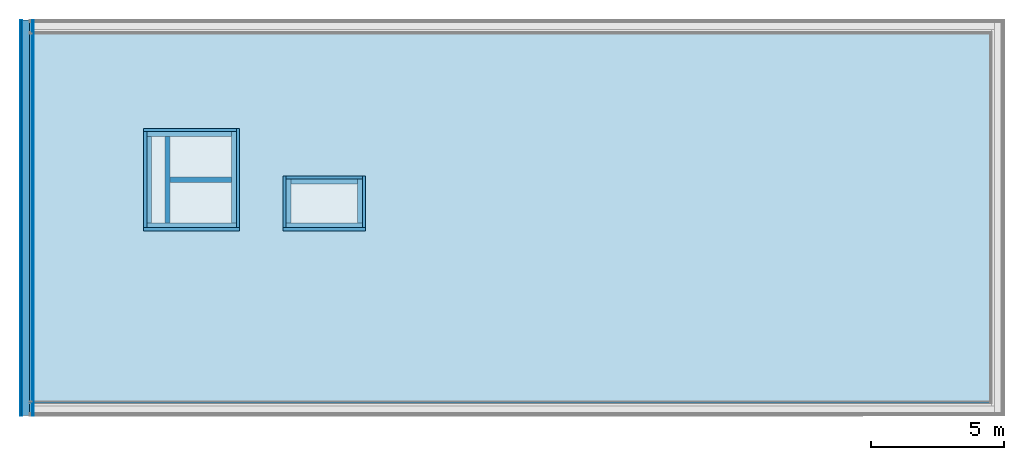
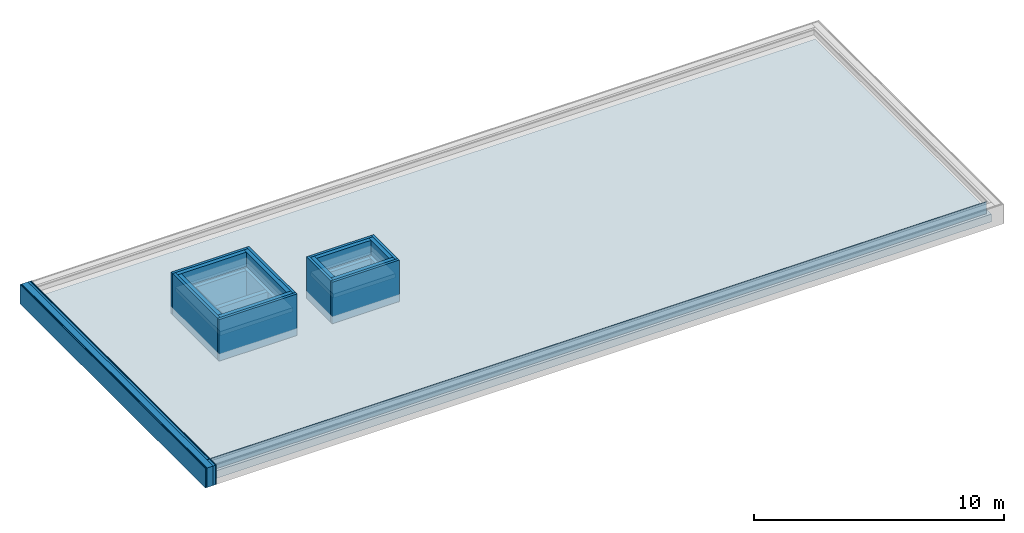
# One storey, part 1 of 3: 25 building element parts, 3 roofs, 2 walls, 10 elements without a shape of their own.
"""IFC4 building model written with IfcOpenShell, lengths in metres."""

from ifc_helpers import new_model, entity, si_unit, converted_unit, derived_unit, direction, frame, origin_with_axes, place, context, subcontext, project, spatial, polygons, material, type_object, element, aggregate, save


model = new_model("IFC4")

# Units and contexts
model_context = context("Model", 3, precision=1e-05, world=origin_with_axes(), true_north=direction((0.0, 1.0)))
body_context = subcontext(model_context, "Body", "Model", "MODEL_VIEW")
ifc_project = project(units=[si_unit("LENGTHUNIT", "METRE"), si_unit("AREAUNIT", "SQUARE_METRE"), si_unit("VOLUMEUNIT", "CUBIC_METRE"), converted_unit("PLANEANGLEUNIT", "DEGREE", entity("IfcPlaneAngleMeasure", 0.0174532925199433), si_unit("PLANEANGLEUNIT", "RADIAN"), dimensions=[0, 0, 0, 0, 0, 0, 0]), converted_unit("TIMEUNIT", "Year", entity("IfcTimeMeasure", 31557600.0), si_unit("TIMEUNIT", "SECOND"), dimensions=[0, 0, 1, 0, 0, 0, 0]), si_unit("MASSUNIT", "GRAM", prefix="KILO"), si_unit("THERMODYNAMICTEMPERATUREUNIT", "DEGREE_CELSIUS"), si_unit("LUMINOUSINTENSITYUNIT", "LUMEN"), si_unit("ENERGYUNIT", "JOULE", prefix="MEGA"), derived_unit("THERMALCONDUCTANCEUNIT", [(si_unit("POWERUNIT", "WATT"), 1), (si_unit("LENGTHUNIT", "METRE"), -1), (si_unit("THERMODYNAMICTEMPERATUREUNIT", "KELVIN"), -1)]), derived_unit("SPECIFICHEATCAPACITYUNIT", [(si_unit("ENERGYUNIT", "JOULE"), 1), (si_unit("MASSUNIT", "GRAM", prefix="KILO"), -1), (si_unit("THERMODYNAMICTEMPERATUREUNIT", "KELVIN"), -1)]), derived_unit("MASSDENSITYUNIT", [(si_unit("MASSUNIT", "GRAM", prefix="KILO"), 1), (si_unit("VOLUMEUNIT", "CUBIC_METRE"), -1)])], contexts=[model_context])

# Site, building, storey
site_placement = place(None, origin_with_axes())
site = spatial("IfcSite", under=ifc_project, at=site_placement, CompositionType="ELEMENT")
building_placement = place(site_placement, origin_with_axes())
building = spatial("IfcBuilding", under=site, at=building_placement, CompositionType="ELEMENT")
storey_placement = place(building_placement, frame((0.0, 0.0, 13.5), z_axis=(0.0, 0.0, 1.0), x_axis=(1.0, 0.0, 0.0)))
storey = spatial("IfcBuildingStorey", under=building, at=storey_placement, Name="Dach", CompositionType="ELEMENT", Elevation=13.5)

# Walls
ifc_material_1 = material(Name="Stahlbeton")
wall_type_1 = type_object("IfcWallType", Name="Stahlbeton 200", PredefinedType="NOTDEFINED")
wall_1_placement = place(storey_placement, frame((29.138, 8.854999945467554, 0.0), z_axis=(0.0, 0.0, 1.0), x_axis=(1.0, 0.0, 0.0)))
element("IfcWall", 1, at=wall_1_placement, inside=storey, type_object=wall_type_1, material=ifc_material_1, Name="Wand-001", PredefinedType="NOTDEFINED", context=body_context, shape_type="Tessellation", body=[
    polygons([(0.0, 0.09999999999999964, 0.0), (2.320000000000004, 0.09999999999999964, 0.0), (2.320000000000004, -0.09999999999999964, 0.0), (0.0, -0.09999999999999964, 0.0), (0.0, 0.09999999999999964, 1.5), (2.320000000000004, 0.09999999999999964, 1.5), (2.320000000000004, -0.09999999999999964, 1.5), (0.0, -0.09999999999999964, 1.5)], [[[1, 2, 3, 4]], [[5, 6, 2, 1]], [[7, 3, 2, 6]], [[4, 3, 7, 8]], [[8, 5, 1, 4]], [[8, 7, 6, 5]]], closed=True),
])
wall_type_2 = type_object("IfcWallType", Name="Stahlbeton 180", PredefinedType="NOTDEFINED")
wall_2_placement = place(storey_placement, frame((29.138, 6.934999945467554, 0.0), z_axis=(0.0, 0.0, 1.0), x_axis=(0.0, 1.0, 0.0)))
element("IfcWall", 2, at=wall_2_placement, inside=storey, type_object=wall_type_2, material=ifc_material_1, Name="Wand-001", PredefinedType="NOTDEFINED", context=body_context, shape_type="Tessellation", body=[
    polygons([(0.2999999999999998, 0.1799999999999997, 0.0), (3.540000000000001, 0.1799999999999997, 0.0), (3.540000000000001, 0.0, 0.0), (0.2999999999999998, 0.0, 0.0), (0.2999999999999998, 0.1799999999999997, 1.5), (3.540000000000001, 0.1799999999999997, 1.5), (3.540000000000001, 0.0, 1.5), (0.2999999999999998, 0.0, 1.5)], [[[1, 2, 3, 4]], [[5, 6, 2, 1]], [[7, 3, 2, 6]], [[4, 3, 7, 8]], [[8, 5, 1, 4]], [[8, 7, 6, 5]]], closed=True),
])

# Roofs
ifc_material_2 = material(Name="Stahlbeton Decke")
roof_type_1 = type_object("IfcRoofType", Name="Stahlbeton Decke 370", PredefinedType="FLAT_ROOF")
roof_1_placement = place(storey_placement, frame((23.88799999999999, 0.3629999999999995, 0.370000000000001), z_axis=(0.0, 0.0, 1.0), x_axis=(1.0, 0.0, 0.0)))
element("IfcRoof", 3, at=roof_1_placement, inside=storey, type_object=roof_type_1, material=ifc_material_2, Name="Decke-001", PredefinedType="FLAT_ROOF", context=body_context, shape_type="Tessellation", body=[
    polygons([(0.0, 0.0, 0.0), (0.0, 0.0, -0.3699999999999992), (36.19499999999999, 0.0, -0.3699999999999992), (36.19499999999999, 0.0, 0.0), (0.0, 14.11999989093511, 0.0), (0.0, 14.11999989093511, -0.3699999999999992), (36.19499999999999, 14.11999989093511, -0.3699999999999992), (7.750000000000011, 10.29199994546755, -0.3699999999999992), (4.390000000000011, 10.29199994546755, -0.3699999999999992), (4.390000000000011, 6.691999945467556, -0.3699999999999992), (7.750000000000011, 6.691999945467556, -0.3699999999999992), (12.485, 6.691999945467553, -0.3699999999999992), (12.485, 8.50999994546756, -0.3699999999999992), (9.617, 8.50999994546756, -0.3699999999999992), (9.617, 6.691999945467553, -0.3699999999999992), (36.19499999999999, 14.11999989093511, 0.0), (4.390000000000011, 6.691999945467556, 0.0), (4.390000000000011, 10.29199994546755, 0.0), (7.750000000000011, 10.29199994546755, 0.0), (7.750000000000011, 6.691999945467556, 0.0), (9.617, 8.50999994546756, 0.0), (12.485, 8.50999994546756, 0.0), (12.485, 6.691999945467553, 0.0), (9.617, 6.691999945467553, 0.0)], [[[1, 2, 3, 4]], [[5, 6, 2, 1]], [[3, 2, 6, 7], [8, 9, 10, 11], [12, 13, 14, 15]], [[4, 3, 7, 16]], [[5, 1, 4, 16], [17, 18, 19, 20], [21, 22, 23, 24]], [[16, 7, 6, 5]], [[18, 9, 8, 19]], [[17, 10, 9, 18]], [[20, 11, 10, 17]], [[19, 8, 11, 20]], [[22, 13, 12, 23]], [[21, 14, 13, 22]], [[24, 15, 14, 21]], [[23, 12, 15, 24]]], closed=True),
])
roof_type_2 = type_object("IfcRoofType", Name="Stahlbeton Decke 200", PredefinedType="FLAT_ROOF")
roof_2_placement = place(storey_placement, frame((28.27800000000001, 7.054999945467558, 1.699999999999999), z_axis=(0.0, 0.0, 1.0), x_axis=(1.0, 0.0, 0.0)))
element("IfcRoof", 4, at=roof_2_placement, inside=storey, type_object=roof_type_2, material=ifc_material_2, Name="Decke-001", PredefinedType="FLAT_ROOF", context=body_context, shape_type="Tessellation", body=[
    polygons([(0.0, 0.0, 0.0), (0.0, 0.0, -0.1999999999999993), (3.359999999999996, 0.0, -0.1999999999999993), (3.359999999999996, 0.0, 0.0), (0.0, 3.599999999999993, 0.0), (0.0, 3.599999999999993, -0.1999999999999993), (3.359999999999996, 3.599999999999993, -0.1999999999999993), (3.359999999999996, 3.599999999999993, 0.0)], [[[1, 2, 3, 4]], [[5, 6, 2, 1]], [[3, 2, 6, 7]], [[4, 3, 7, 8]], [[5, 1, 4, 8]], [[8, 7, 6, 5]]], closed=True),
])
roof_3_placement = place(storey_placement, frame((33.505, 7.054999945467557, 1.699999999999999), z_axis=(0.0, 0.0, 1.0), x_axis=(1.0, 0.0, 0.0)))
element("IfcRoof", 5, at=roof_3_placement, inside=storey, type_object=roof_type_2, material=ifc_material_2, Name="Decke-001", PredefinedType="FLAT_ROOF", context=body_context, shape_type="Tessellation", body=[
    polygons([(0.0, 0.0, 0.0), (0.0, 0.0, -0.1999999999999993), (2.868000000000002, 0.0, -0.1999999999999993), (2.868000000000002, 0.0, 0.0), (0.0, 1.818000000000003, 0.0), (0.0, 1.818000000000003, -0.1999999999999993), (2.868000000000002, 1.818000000000003, -0.1999999999999993), (2.868000000000002, 1.818000000000003, 0.0)], [[[1, 2, 3, 4]], [[5, 6, 2, 1]], [[3, 2, 6, 7]], [[4, 3, 7, 8]], [[5, 1, 4, 8]], [[8, 7, 6, 5]]], closed=True),
])

# Wall, building element parts
wall_type_3 = type_object("IfcWallType", Name="AW 300", PredefinedType="NOTDEFINED")
wall_3_placement = place(storey_placement, frame((28.158, 6.934999945467554, 0.0), z_axis=(0.0, 0.0, 1.0), x_axis=(1.0, 0.0, 0.0)))
wall_3 = element("IfcWall", 6, at=wall_3_placement, inside=storey, type_object=wall_type_3, Name="Wand-001", PredefinedType="NOTDEFINED")
ifc_material_3 = material(Name="Stahlbeton Wand")
building_element_part_1_placement = place(wall_3_placement, origin_with_axes())
building_element_part_1 = element("IfcBuildingElementPart", 7, at=building_element_part_1_placement, material=ifc_material_3, Name="Stahlbeton Wand", PredefinedType="NOTDEFINED", context=body_context, shape_type="Tessellation", body=[
    polygons([(0.1200000000000045, 0.2999999999999998, 1.5), (3.48, 0.3000000000000016, 1.5), (3.48, 0.3000000000000007, 0.0), (0.1199999999999974, 0.2999999999999998, 0.0), (3.480000000000004, 0.1200000000000045, 1.5), (0.1200000000000081, 0.1200000000000037, 1.5), (3.480000000000004, 0.120000000000001, 0.0), (0.120000000000001, 0.1200000000000001, 0.0)], [[[1, 2, 3, 4]], [[5, 2, 1, 6]], [[2, 5, 7, 3]], [[3, 7, 8, 4]], [[6, 1, 4, 8]], [[5, 6, 8, 7]]], closed=True),
    polygons([(3.480000000000004, 0.1200000000000045, 1.699999999999999), (3.48, 0.3000000000000016, 1.699999999999999), (3.48, 0.3000000000000016, 2.4), (3.480000000000004, 0.120000000000001, 2.4), (0.1200000000000045, 0.2999999999999998, 1.699999999999999), (0.1200000000000081, 0.1200000000000037, 1.699999999999999), (0.1199999999999974, 0.2999999999999998, 2.4), (0.120000000000001, 0.1200000000000001, 2.4)], [[[1, 2, 3, 4]], [[5, 2, 1, 6]], [[2, 5, 7, 3]], [[4, 3, 7, 8]], [[6, 1, 4, 8]], [[5, 6, 8, 7]]], closed=True),
])
ifc_material_4 = material(Name="XPS")
building_element_part_2_placement = place(wall_3_placement, origin_with_axes())
building_element_part_2 = element("IfcBuildingElementPart", 8, at=building_element_part_2_placement, material=ifc_material_4, Name="XPS", PredefinedType="NOTDEFINED", context=body_context, shape_type="Tessellation", body=[
    polygons([(3.600000000000005, 0.0, 0.370000000000001), (3.600000000000005, 0.120000000000001, 0.370000000000001), (3.600000000000005, 0.120000000000001, 2.4), (3.600000000000005, 0.0, 2.4), (3.480000000000004, 0.1200000000000019, 0.370000000000001), (0.0, 0.0, 0.370000000000001), (0.0, 0.1200000000000001, 0.370000000000001), (0.1200000000000045, 0.120000000000001, 0.370000000000001), (0.0, 0.1200000000000001, 2.4), (0.0, 0.0, 2.4)], [[[1, 2, 3, 4]], [[5, 2, 1, 6, 7, 8]], [[8, 7, 9, 3, 2, 5]], [[4, 3, 9, 10]], [[6, 1, 4, 10]], [[7, 6, 10, 9]]], closed=True),
])
aggregate(wall_3, [building_element_part_1, building_element_part_2])

# Wall, building element part
wall_4_placement = place(storey_placement, frame((31.75800000000001, 6.934999945467553, 0.0), z_axis=(0.0, 0.0, 1.0), x_axis=(0.0, 1.0, 0.0)))
wall_4 = element("IfcWall", 9, at=wall_4_placement, inside=storey, type_object=wall_type_3, Name="Wand-002", PredefinedType="NOTDEFINED")
building_element_part_3_placement = place(wall_4_placement, origin_with_axes())
building_element_part_3 = element("IfcBuildingElementPart", 10, at=building_element_part_3_placement, material=ifc_material_3, Name="Stahlbeton Wand", PredefinedType="NOTDEFINED", context=body_context, shape_type="Tessellation", body=[
    polygons([(3.719999999999999, 0.2999999999999972, 1.5), (3.719999999999999, 0.1199999999999974, 1.5), (3.720000000000004, 0.1199999999999974, 0.0), (3.720000000000004, 0.2999999999999972, 0.0), (0.2999999999999998, 0.120000000000001, 1.5), (0.2999999999999998, 0.3000000000000007, 1.5), (0.2999999999999998, 0.120000000000001, 0.0), (0.2999999999999998, 0.3000000000000007, 0.0)], [[[1, 2, 3, 4]], [[5, 2, 1, 6]], [[2, 5, 7, 3]], [[4, 3, 7, 8]], [[6, 1, 4, 8]], [[5, 6, 8, 7]]], closed=True),
    polygons([(0.2999999999999998, 0.120000000000001, 1.699999999999999), (3.719999999999999, 0.1199999999999974, 1.699999999999999), (3.720000000000004, 0.1199999999999974, 2.4), (0.2999999999999998, 0.120000000000001, 2.4), (3.719999999999999, 0.2999999999999972, 1.699999999999999), (0.2999999999999998, 0.3000000000000007, 1.699999999999999), (3.720000000000004, 0.2999999999999972, 2.4), (0.2999999999999998, 0.3000000000000007, 2.4)], [[[1, 2, 3, 4]], [[5, 2, 1, 6]], [[2, 5, 7, 3]], [[3, 7, 8, 4]], [[6, 1, 4, 8]], [[5, 6, 8, 7]]], closed=True),
])

# Wall, building element parts
wall_5_placement = place(storey_placement, frame((31.758, 10.77499994546756, 0.0), z_axis=(0.0, 0.0, 1.0), x_axis=(-1.0, 0.0, 0.0)))
wall_5 = element("IfcWall", 11, at=wall_5_placement, inside=storey, type_object=wall_type_3, Name="Wand-003", PredefinedType="NOTDEFINED")
building_element_part_4_placement = place(wall_5_placement, origin_with_axes())
building_element_part_4 = element("IfcBuildingElementPart", 12, at=building_element_part_4_placement, material=ifc_material_3, Name="Stahlbeton Wand", PredefinedType="NOTDEFINED", context=body_context, shape_type="Tessellation", body=[
    polygons([(3.479999999999993, 0.1200000000000045, 1.5), (0.3000000000000007, 0.1200000000000045, 1.5), (0.3000000000000007, 0.1199999999999992, 0.0), (3.479999999999997, 0.1199999999999992, 0.0), (0.3000000000000007, 0.3000000000000007, 1.5), (3.479999999999993, 0.3000000000000007, 1.5), (0.3000000000000007, 0.3000000000000007, 0.0), (3.479999999999997, 0.2999999999999989, 0.0)], [[[1, 2, 3, 4]], [[5, 2, 1, 6]], [[2, 5, 7, 3]], [[8, 4, 3, 7]], [[6, 1, 4, 8]], [[5, 6, 8, 7]]], closed=True),
    polygons([(0.3000000000000007, 0.3000000000000007, 1.699999999999999), (0.3000000000000007, 0.1200000000000045, 1.699999999999999), (0.3000000000000007, 0.120000000000001, 2.4), (0.3000000000000007, 0.3000000000000007, 2.4), (3.479999999999993, 0.1200000000000045, 1.699999999999999), (3.479999999999993, 0.3000000000000007, 1.699999999999999), (3.479999999999997, 0.1199999999999992, 2.4), (3.479999999999997, 0.3000000000000007, 2.4)], [[[1, 2, 3, 4]], [[5, 2, 1, 6]], [[2, 5, 7, 3]], [[7, 8, 4, 3]], [[6, 1, 4, 8]], [[5, 6, 8, 7]]], closed=True),
])
building_element_part_5_placement = place(wall_5_placement, origin_with_axes())
building_element_part_5 = element("IfcBuildingElementPart", 13, at=building_element_part_5_placement, material=ifc_material_4, Name="XPS", PredefinedType="NOTDEFINED", context=body_context, shape_type="Tessellation", body=[
    polygons([(0.1199999999999974, 0.1200000000000045, 0.370000000000001), (0.120000000000001, 0.0, 0.370000000000001), (0.120000000000001, 0.0, 2.4), (0.120000000000001, 0.120000000000001, 2.4), (3.599999999999998, 0.0, 0.370000000000001), (3.479999999999997, 0.1200000000000045, 0.370000000000001), (3.599999999999998, 0.1199999999999992, 0.370000000000001), (3.599999999999998, 0.0, 2.4), (3.599999999999998, 0.1199999999999992, 2.4)], [[[1, 2, 3, 4]], [[5, 2, 1, 6, 7]], [[2, 5, 8, 3]], [[8, 9, 4, 3]], [[6, 1, 4, 9, 7]], [[5, 7, 9, 8]]], closed=True),
])
aggregate(wall_5, [building_element_part_4, building_element_part_5])

wall_6_placement = place(storey_placement, frame((28.158, 6.934999945467554, 0.0), z_axis=(0.0, 0.0, 1.0), x_axis=(0.0, 1.0, 0.0)))
wall_6 = element("IfcWall", 14, at=wall_6_placement, inside=storey, type_object=wall_type_3, Name="Wand-002", PredefinedType="NOTDEFINED")
building_element_part_6_placement = place(wall_6_placement, origin_with_axes())
building_element_part_6 = element("IfcBuildingElementPart", 15, at=building_element_part_6_placement, material=ifc_material_4, Name="XPS", PredefinedType="NOTDEFINED", context=body_context, shape_type="Tessellation", body=[
    polygons([(0.120000000000001, -0.1200000000000045, 0.370000000000001), (3.719999999999998, -0.120000000000001, 0.370000000000001), (3.720000000000003, -0.1199999999999974, 2.4), (0.1200000000000001, -0.120000000000001, 2.4), (3.720000000000003, 0.0, 0.370000000000001), (0.1200000000000001, 0.0, 0.370000000000001), (3.720000000000003, 0.0, 2.4), (0.1200000000000001, 0.0, 2.4)], [[[1, 2, 3, 4]], [[5, 2, 1, 6]], [[2, 5, 7, 3]], [[3, 7, 8, 4]], [[6, 1, 4, 8]], [[5, 6, 8, 7]]], closed=True),
])
building_element_part_7_placement = place(wall_6_placement, origin_with_axes())
building_element_part_7 = element("IfcBuildingElementPart", 16, at=building_element_part_7_placement, material=ifc_material_3, Name="Stahlbeton Wand", PredefinedType="NOTDEFINED", context=body_context, shape_type="Tessellation", body=[
    polygons([(3.540000000000002, -0.1200000000000045, 1.5), (3.540000000000002, -0.2999999999999972, 1.5), (3.540000000000002, -0.2999999999999972, 0.0), (3.540000000000002, -0.1199999999999974, 0.0), (0.3000000000000007, -0.3000000000000007, 1.5), (0.2999999999999998, -0.1200000000000081, 1.5), (0.3000000000000007, -0.3000000000000007, 0.0), (0.2999999999999998, -0.120000000000001, 0.0)], [[[1, 2, 3, 4]], [[5, 2, 1, 6]], [[2, 5, 7, 3]], [[4, 3, 7, 8]], [[6, 1, 4, 8]], [[5, 6, 8, 7]]], closed=True),
    polygons([(0.3000000000000007, -0.3000000000000007, 1.699999999999999), (3.540000000000002, -0.2999999999999972, 1.699999999999999), (3.540000000000002, -0.2999999999999972, 2.4), (0.3000000000000007, -0.3000000000000007, 2.4), (3.540000000000002, -0.1200000000000045, 1.699999999999999), (0.2999999999999998, -0.1200000000000081, 1.699999999999999), (3.540000000000002, -0.1199999999999974, 2.4), (0.2999999999999998, -0.120000000000001, 2.4)], [[[1, 2, 3, 4]], [[5, 2, 1, 6]], [[2, 5, 7, 3]], [[3, 7, 8, 4]], [[6, 1, 4, 8]], [[5, 6, 8, 7]]], closed=True),
])
aggregate(wall_6, [building_element_part_6, building_element_part_7])

# Building element part
building_element_part_8_placement = place(wall_4_placement, origin_with_axes())
building_element_part_8 = element("IfcBuildingElementPart", 17, at=building_element_part_8_placement, material=ifc_material_4, Name="XPS", PredefinedType="NOTDEFINED", context=body_context, shape_type="Tessellation", body=[
    polygons([(0.1200000000000001, 0.0, 0.370000000000001), (3.840000000000002, 0.0, 0.370000000000001), (3.840000000000002, 0.0, 2.4), (0.1200000000000001, 0.0, 2.4), (3.840000000000003, 0.1199999999999974, 0.370000000000001), (0.1200000000000019, 0.120000000000001, 0.370000000000001), (3.719999999999999, 0.1199999999999974, 0.370000000000001), (3.840000000000003, 0.1199999999999974, 2.4), (0.1200000000000001, 0.120000000000001, 2.4)], [[[1, 2, 3, 4]], [[5, 2, 1, 6, 7]], [[2, 5, 8, 3]], [[3, 8, 9, 4]], [[6, 1, 4, 9]], [[7, 6, 9, 8, 5]]], closed=True),
])

aggregate(wall_4, [building_element_part_3, building_element_part_8])

# Wall, building element parts
wall_7_placement = place(storey_placement, frame((36.49299999999999, 6.934999945467555, 0.0), z_axis=(0.0, 0.0, 1.0), x_axis=(0.0, 1.0, 0.0)))
wall_7 = element("IfcWall", 18, at=wall_7_placement, inside=storey, type_object=wall_type_3, Name="Wand-002", PredefinedType="NOTDEFINED")
building_element_part_9_placement = place(wall_7_placement, origin_with_axes())
building_element_part_9 = element("IfcBuildingElementPart", 19, at=building_element_part_9_placement, material=ifc_material_3, Name="Stahlbeton Wand", PredefinedType="NOTDEFINED", context=body_context, shape_type="Tessellation", body=[
    polygons([(1.938000000000005, 0.2999999999999972, 1.5), (1.938000000000005, 0.1199999999999974, 1.5), (1.938000000000005, 0.1199999999999974, 0.0), (1.938000000000005, 0.2999999999999972, 0.0), (0.2999999999999998, 0.1199999999999974, 1.5), (0.2999999999999998, 0.2999999999999972, 1.5), (0.2999999999999998, 0.1199999999999974, 0.0), (0.2999999999999998, 0.2999999999999972, 0.0)], [[[1, 2, 3, 4]], [[5, 2, 1, 6]], [[2, 5, 7, 3]], [[4, 3, 7, 8]], [[6, 1, 4, 8]], [[5, 6, 8, 7]]], closed=True),
    polygons([(0.2999999999999998, 0.1199999999999974, 1.699999999999999), (1.938000000000005, 0.1199999999999974, 1.699999999999999), (1.938000000000005, 0.1199999999999974, 2.4), (0.2999999999999998, 0.1199999999999974, 2.4), (1.938000000000005, 0.2999999999999972, 1.699999999999999), (0.2999999999999998, 0.2999999999999972, 1.699999999999999), (1.938000000000005, 0.2999999999999972, 2.4), (0.2999999999999998, 0.2999999999999972, 2.4)], [[[1, 2, 3, 4]], [[5, 2, 1, 6]], [[2, 5, 7, 3]], [[3, 7, 8, 4]], [[6, 1, 4, 8]], [[5, 6, 8, 7]]], closed=True),
])
building_element_part_10_placement = place(wall_7_placement, origin_with_axes())
building_element_part_10 = element("IfcBuildingElementPart", 20, at=building_element_part_10_placement, material=ifc_material_4, Name="XPS", PredefinedType="NOTDEFINED", context=body_context, shape_type="Tessellation", body=[
    polygons([(0.1200000000000001, 0.0, 0.370000000000001), (2.058000000000004, 0.0, 0.370000000000001), (2.058000000000004, 0.0, 2.4), (0.1200000000000001, 0.0, 2.4), (2.058000000000004, 0.1199999999999974, 0.370000000000001), (0.1199999999999974, 0.1199999999999974, 0.370000000000001), (1.938000000000005, 0.1199999999999974, 0.370000000000001), (2.058000000000004, 0.1199999999999974, 2.4), (0.1200000000000001, 0.1199999999999974, 2.4)], [[[1, 2, 3, 4]], [[5, 2, 1, 6, 7]], [[2, 5, 8, 3]], [[3, 8, 9, 4]], [[6, 1, 4, 9]], [[7, 6, 9, 8, 5]]], closed=True),
])
aggregate(wall_7, [building_element_part_9, building_element_part_10])

wall_8_placement = place(storey_placement, frame((36.49299999999999, 8.99299994546756, 0.0), z_axis=(0.0, 0.0, 1.0), x_axis=(-1.0, 0.0, 0.0)))
wall_8 = element("IfcWall", 21, at=wall_8_placement, inside=storey, type_object=wall_type_3, Name="Wand-002", PredefinedType="NOTDEFINED")
building_element_part_11_placement = place(wall_8_placement, origin_with_axes())
building_element_part_11 = element("IfcBuildingElementPart", 22, at=building_element_part_11_placement, material=ifc_material_4, Name="XPS", PredefinedType="NOTDEFINED", context=body_context, shape_type="Tessellation", body=[
    polygons([(0.1199999999999974, 0.1199999999999992, 0.370000000000001), (0.1199999999999974, 0.0, 0.370000000000001), (0.1199999999999974, 0.0, 2.4), (0.1199999999999974, 0.120000000000001, 2.4), (2.988, 0.0, 0.370000000000001), (2.988, 0.1199999999999992, 0.370000000000001), (2.988, 0.0, 2.4), (2.988, 0.1199999999999992, 2.4)], [[[1, 2, 3, 4]], [[5, 2, 1, 6]], [[2, 5, 7, 3]], [[7, 8, 4, 3]], [[6, 1, 4, 8]], [[5, 6, 8, 7]]], closed=True),
])
building_element_part_12_placement = place(wall_8_placement, origin_with_axes())
building_element_part_12 = element("IfcBuildingElementPart", 23, at=building_element_part_12_placement, material=ifc_material_3, Name="Stahlbeton Wand", PredefinedType="NOTDEFINED", context=body_context, shape_type="Tessellation", body=[
    polygons([(2.808, 0.1199999999999992, 1.5), (0.2999999999999972, 0.1199999999999992, 1.5), (0.2999999999999972, 0.1199999999999992, 0.0), (2.808, 0.1199999999999992, 0.0), (0.2999999999999972, 0.3000000000000007, 1.5), (2.808, 0.3000000000000007, 1.5), (0.2999999999999972, 0.3000000000000007, 0.0), (2.808, 0.2999999999999989, 0.0)], [[[1, 2, 3, 4]], [[5, 2, 1, 6]], [[2, 5, 7, 3]], [[8, 4, 3, 7]], [[6, 1, 4, 8]], [[5, 6, 8, 7]]], closed=True),
    polygons([(0.2999999999999972, 0.3000000000000007, 1.699999999999999), (0.2999999999999972, 0.1199999999999992, 1.699999999999999), (0.2999999999999972, 0.120000000000001, 2.4), (0.2999999999999972, 0.3000000000000007, 2.4), (2.808, 0.1199999999999992, 1.699999999999999), (2.808, 0.3000000000000007, 1.699999999999999), (2.808, 0.1199999999999992, 2.4), (2.808, 0.3000000000000007, 2.4)], [[[1, 2, 3, 4]], [[5, 2, 1, 6]], [[2, 5, 7, 3]], [[7, 8, 4, 3]], [[6, 1, 4, 8]], [[5, 6, 8, 7]]], closed=True),
])
aggregate(wall_8, [building_element_part_11, building_element_part_12])

# Wall, building element part
wall_9_placement = place(storey_placement, frame((33.385, 6.934999945467555, 0.0), z_axis=(0.0, 0.0, 1.0), x_axis=(1.0, 0.0, 0.0)))
wall_9 = element("IfcWall", 24, at=wall_9_placement, inside=storey, type_object=wall_type_3, Name="Wand-002", PredefinedType="NOTDEFINED")
building_element_part_13_placement = place(wall_9_placement, origin_with_axes())
building_element_part_13 = element("IfcBuildingElementPart", 25, at=building_element_part_13_placement, material=ifc_material_4, Name="XPS", PredefinedType="NOTDEFINED", context=body_context, shape_type="Tessellation", body=[
    polygons([(3.107999999999997, 0.0, 0.370000000000001), (3.107999999999997, 0.1200000000000001, 0.370000000000001), (3.107999999999997, 0.1200000000000001, 2.4), (3.107999999999997, 0.0, 2.4), (2.988, 0.1199999999999974, 0.370000000000001), (0.0, 0.0, 0.370000000000001), (0.0, 0.1200000000000001, 0.370000000000001), (0.1199999999999974, 0.1199999999999974, 0.370000000000001), (0.0, 0.1200000000000001, 2.4), (0.0, 0.0, 2.4)], [[[1, 2, 3, 4]], [[5, 2, 1, 6, 7, 8]], [[8, 7, 9, 3, 2, 5]], [[4, 3, 9, 10]], [[6, 1, 4, 10]], [[7, 6, 10, 9]]], closed=True),
])

wall_10_placement = place(storey_placement, frame((33.385, 6.934999945467555, 0.0), z_axis=(0.0, 0.0, 1.0), x_axis=(0.0, 1.0, 0.0)))
wall_10 = element("IfcWall", 26, at=wall_10_placement, inside=storey, type_object=wall_type_3, Name="Wand-002", PredefinedType="NOTDEFINED")
building_element_part_14_placement = place(wall_10_placement, origin_with_axes())
building_element_part_14 = element("IfcBuildingElementPart", 27, at=building_element_part_14_placement, material=ifc_material_4, Name="XPS", PredefinedType="NOTDEFINED", context=body_context, shape_type="Tessellation", body=[
    polygons([(0.1199999999999974, -0.1199999999999974, 0.370000000000001), (1.938000000000005, -0.1199999999999974, 0.370000000000001), (2.058000000000004, -0.1199999999999974, 0.370000000000001), (2.058000000000004, -0.1199999999999974, 2.4), (0.1200000000000001, -0.1199999999999974, 2.4), (2.058000000000004, 0.0, 0.370000000000001), (0.1200000000000001, 0.0, 0.370000000000001), (2.058000000000004, 0.0, 2.4), (0.1200000000000001, 0.0, 2.4)], [[[1, 2, 3, 4, 5]], [[6, 3, 2, 1, 7]], [[3, 6, 8, 4]], [[4, 8, 9, 5]], [[7, 1, 5, 9]], [[6, 7, 9, 8]]], closed=True),
])

# Building element part
building_element_part_15_placement = place(wall_9_placement, origin_with_axes())
building_element_part_15 = element("IfcBuildingElementPart", 28, at=building_element_part_15_placement, material=ifc_material_3, Name="Stahlbeton Wand", PredefinedType="NOTDEFINED", context=body_context, shape_type="Tessellation", body=[
    polygons([(0.1199999999999974, 0.2999999999999998, 1.5), (2.988, 0.3000000000000007, 1.5), (2.988, 0.2999999999999998, 0.0), (0.1199999999999974, 0.2999999999999998, 0.0), (2.988, 0.1200000000000019, 1.5), (0.1199999999999974, 0.1200000000000019, 1.5), (2.988, 0.1200000000000001, 0.0), (0.1199999999999974, 0.1200000000000001, 0.0)], [[[1, 2, 3, 4]], [[5, 2, 1, 6]], [[2, 5, 7, 3]], [[3, 7, 8, 4]], [[6, 1, 4, 8]], [[5, 6, 8, 7]]], closed=True),
    polygons([(2.988, 0.1200000000000019, 1.699999999999999), (2.988, 0.3000000000000007, 1.699999999999999), (2.988, 0.3000000000000007, 2.4), (2.988, 0.1200000000000001, 2.4), (0.1199999999999974, 0.2999999999999998, 1.699999999999999), (0.1199999999999974, 0.1200000000000019, 1.699999999999999), (0.1199999999999974, 0.2999999999999998, 2.4), (0.1199999999999974, 0.1200000000000001, 2.4)], [[[1, 2, 3, 4]], [[5, 2, 1, 6]], [[2, 5, 7, 3]], [[4, 3, 7, 8]], [[6, 1, 4, 8]], [[5, 6, 8, 7]]], closed=True),
])

aggregate(wall_9, [building_element_part_13, building_element_part_15])

building_element_part_16_placement = place(wall_10_placement, origin_with_axes())
building_element_part_16 = element("IfcBuildingElementPart", 29, at=building_element_part_16_placement, material=ifc_material_3, Name="Stahlbeton Wand", PredefinedType="NOTDEFINED", context=body_context, shape_type="Tessellation", body=[
    polygons([(1.938000000000005, -0.1199999999999974, 1.5), (1.938000000000005, -0.2999999999999972, 1.5), (1.938000000000005, -0.2999999999999972, 0.0), (1.938000000000005, -0.1199999999999974, 0.0), (0.2999999999999998, -0.2999999999999972, 1.5), (0.2999999999999998, -0.1199999999999974, 1.5), (0.2999999999999998, -0.2999999999999972, 0.0), (0.2999999999999998, -0.1199999999999974, 0.0)], [[[1, 2, 3, 4]], [[5, 2, 1, 6]], [[2, 5, 7, 3]], [[4, 3, 7, 8]], [[6, 1, 4, 8]], [[5, 6, 8, 7]]], closed=True),
    polygons([(0.2999999999999998, -0.2999999999999972, 1.699999999999999), (1.938000000000005, -0.2999999999999972, 1.699999999999999), (1.938000000000005, -0.2999999999999972, 2.4), (0.2999999999999998, -0.2999999999999972, 2.4), (1.938000000000005, -0.1199999999999974, 1.699999999999999), (0.2999999999999998, -0.1199999999999974, 1.699999999999999), (1.938000000000005, -0.1199999999999974, 2.4), (0.2999999999999998, -0.1199999999999974, 2.4)], [[[1, 2, 3, 4]], [[5, 2, 1, 6]], [[2, 5, 7, 3]], [[3, 7, 8, 4]], [[6, 1, 4, 8]], [[5, 6, 8, 7]]], closed=True),
])

aggregate(wall_10, [building_element_part_14, building_element_part_16])

# Wall, building element part
wall_type_4 = type_object("IfcWallType", Name="04a-00 520", PredefinedType="NOTDEFINED")
wall_11_placement = place(storey_placement, frame((23.88799999999999, 0.0, 0.0), z_axis=(0.0, 0.0, 1.0), x_axis=(1.0, 0.0, 0.0)))
wall_11 = element("IfcWall", 30, at=wall_11_placement, inside=storey, type_object=wall_type_4, PredefinedType="NOTDEFINED")
ifc_material_5 = material(Name="din_18948")
building_element_part_17_placement = place(wall_11_placement, origin_with_axes())
building_element_part_17 = element("IfcBuildingElementPart", 31, at=building_element_part_17_placement, material=ifc_material_5, Name="din_18948", PredefinedType="NOTDEFINED", context=body_context, shape_type="Tessellation", body=[
    polygons([(36.04300000000001, 0.4930000000000023, 0.0), (0.0, 0.4930000000000001, 0.0), (0.0, 0.5150000000000001, 0.0), (36.04300000000001, 0.5150000000000023, 0.0), (36.04300000000001, 0.4930000000000023, 0.9500000000000028), (0.0, 0.4930000000000002, 0.9500000000000028), (0.0, 0.5150000000000002, 0.9500000000000028), (36.04300000000001, 0.5150000000000025, 0.9500000000000028)], [[[1, 2, 3, 4]], [[5, 6, 2, 1]], [[3, 2, 6, 7]], [[4, 3, 7, 8]], [[4, 8, 5, 1]], [[8, 7, 6, 5]]], closed=True),
])
aggregate(wall_11, [building_element_part_17])

# Wall, building element parts
wall_12_placement = place(storey_placement, frame((23.518, 14.8459998854578, 0.0), z_axis=(0.0, 0.0, 1.0), x_axis=(0.0, -1.0, 0.0)))
wall_12 = element("IfcWall", 32, at=wall_12_placement, inside=storey, type_object=wall_type_4, PredefinedType="NOTDEFINED")
building_element_part_18_placement = place(wall_12_placement, origin_with_axes())
building_element_part_18 = element("IfcBuildingElementPart", 33, at=building_element_part_18_placement, material=ifc_material_5, Name="din_18948", PredefinedType="NOTDEFINED", context=body_context, shape_type="Tessellation", body=[
    polygons([(14.8459998854578, 0.5150000000000006, 0.0), (14.8459998854578, 0.4930000000000021, 0.0), (0.0, 0.4929999999999986, 0.0), (0.0, 0.5150000000000006, 0.0), (14.8459998854578, 0.5150000000000006, 0.9500000000000028), (14.8459998854578, 0.4930000000000021, 0.9500000000000028), (0.0, 0.4929999999999986, 0.9500000000000028), (0.0, 0.5150000000000006, 0.9500000000000028)], [[[1, 2, 3, 4]], [[1, 5, 6, 2]], [[2, 6, 7, 3]], [[4, 3, 7, 8]], [[5, 1, 4, 8]], [[6, 5, 8, 7]]], closed=True),
])
ifc_material_6 = material(Name="holz_fichte")
building_element_part_19_placement = place(wall_12_placement, origin_with_axes())
building_element_part_19 = element("IfcBuildingElementPart", 34, at=building_element_part_19_placement, material=ifc_material_6, Name="holz_fichte", PredefinedType="NOTDEFINED", context=body_context, shape_type="Tessellation", body=[
    polygons([(14.8459998854578, 0.4930000000000021, 0.0), (14.8459998854578, 0.463000000000001, 0.0), (0.0, 0.463000000000001, 0.0), (0.0, 0.4929999999999986, 0.0), (14.8459998854578, 0.4930000000000021, 0.9500000000000028), (14.8459998854578, 0.463000000000001, 0.9500000000000028), (0.0, 0.463000000000001, 0.9500000000000028), (0.0, 0.4929999999999986, 0.9500000000000028)], [[[1, 2, 3, 4]], [[1, 5, 6, 2]], [[2, 6, 7, 3]], [[4, 3, 7, 8]], [[5, 1, 4, 8]], [[6, 5, 8, 7]]], closed=True),
])
ifc_material_7 = material()
building_element_part_20_placement = place(wall_12_placement, origin_with_axes())
building_element_part_20 = element("IfcBuildingElementPart", 35, at=building_element_part_20_placement, material=ifc_material_7, PredefinedType="NOTDEFINED", context=body_context, shape_type="Tessellation", body=[
    polygons([(14.8459998854578, 0.3630000000000031, 0.0), (14.8459998854578, 0.08300000000000196, 0.0), (0.0, 0.08299999999999841, 0.0), (0.0, 0.3629999999999995, 0.0), (14.8459998854578, 0.3630000000000031, 0.9500000000000028), (14.8459998854578, 0.08300000000000196, 0.9500000000000028), (0.0, 0.08299999999999841, 0.9500000000000028), (0.0, 0.3629999999999995, 0.9500000000000028)], [[[1, 2, 3, 4]], [[1, 5, 6, 2]], [[2, 6, 7, 3]], [[4, 3, 7, 8]], [[5, 1, 4, 8]], [[6, 5, 8, 7]]], closed=True),
])
ifc_material_8 = material(Name="5")
building_element_part_21_placement = place(wall_12_placement, origin_with_axes())
building_element_part_21 = element("IfcBuildingElementPart", 36, at=building_element_part_21_placement, material=ifc_material_8, Name="5", PredefinedType="NOTDEFINED", context=body_context, shape_type="Tessellation", body=[
    polygons([(14.8459998854578, 0.463000000000001, 0.0), (14.8459998854578, 0.3630000000000031, 0.0), (0.0, 0.3629999999999995, 0.0), (0.0, 0.463000000000001, 0.0), (14.8459998854578, 0.463000000000001, 0.9500000000000028), (14.8459998854578, 0.3630000000000031, 0.9500000000000028), (0.0, 0.3629999999999995, 0.9500000000000028), (0.0, 0.463000000000001, 0.9500000000000028)], [[[1, 2, 3, 4]], [[1, 5, 6, 2]], [[2, 6, 7, 3]], [[4, 3, 7, 8]], [[5, 1, 4, 8]], [[6, 5, 8, 7]]], closed=True),
])
ifc_material_9 = material(Name="mit")
building_element_part_22_placement = place(wall_12_placement, origin_with_axes())
building_element_part_22 = element("IfcBuildingElementPart", 37, at=building_element_part_22_placement, material=ifc_material_9, Name="mit", PredefinedType="NOTDEFINED", context=body_context, shape_type="Tessellation", body=[
    polygons([(14.8459998854578, 0.5200000000000031, 0.0), (14.8459998854578, 0.5150000000000006, 0.0), (0.0, 0.5150000000000006, 0.0), (0.0, 0.5199999999999996, 0.0), (14.8459998854578, 0.5200000000000031, 0.9500000000000028), (14.8459998854578, 0.5150000000000006, 0.9500000000000028), (0.0, 0.5150000000000006, 0.9500000000000028), (0.0, 0.5199999999999996, 0.9500000000000028)], [[[1, 2, 3, 4]], [[1, 5, 6, 2]], [[2, 6, 7, 3]], [[4, 3, 7, 8]], [[5, 1, 4, 8]], [[6, 5, 8, 7]]], closed=True),
])
ifc_material_10 = material(Name="fichte")
building_element_part_23_placement = place(wall_12_placement, origin_with_axes())
building_element_part_23 = element("IfcBuildingElementPart", 38, at=building_element_part_23_placement, material=ifc_material_10, Name="fichte", PredefinedType="NOTDEFINED", context=body_context, shape_type="Tessellation", body=[
    polygons([(14.8459998854578, 0.08300000000000196, 0.0), (14.8459998854578, 0.05900000000000105, 0.0), (0.0, 0.05900000000000105, 0.0), (0.0, 0.08299999999999841, 0.0), (14.8459998854578, 0.08300000000000196, 0.9500000000000028), (14.8459998854578, 0.05900000000000105, 0.9500000000000028), (0.0, 0.05900000000000105, 0.9500000000000028), (0.0, 0.08299999999999841, 0.9500000000000028)], [[[1, 2, 3, 4]], [[1, 5, 6, 2]], [[2, 6, 7, 3]], [[4, 3, 7, 8]], [[5, 1, 4, 8]], [[6, 5, 8, 7]]], closed=True),
])
ifc_material_11 = material()
building_element_part_24_placement = place(wall_12_placement, origin_with_axes())
building_element_part_24 = element("IfcBuildingElementPart", 39, at=building_element_part_24_placement, material=ifc_material_11, PredefinedType="NOTDEFINED", context=body_context, shape_type="Tessellation", body=[
    polygons([(14.8459998854578, 0.0190000000000019, 0.0), (14.8459998854578, 0.0, 0.0), (0.0, 0.0, 0.0), (0.0, 0.01899999999999835, 0.0), (14.8459998854578, 0.0190000000000019, 0.9500000000000028), (14.8459998854578, 0.0, 0.9500000000000028), (0.0, 0.0, 0.9500000000000028), (0.0, 0.01899999999999835, 0.9500000000000028)], [[[1, 2, 3, 4]], [[1, 5, 6, 2]], [[2, 6, 7, 3]], [[4, 3, 7, 8]], [[5, 1, 4, 8]], [[6, 5, 8, 7]]], closed=True),
])
building_element_part_25_placement = place(wall_12_placement, origin_with_axes())
building_element_part_25 = element("IfcBuildingElementPart", 40, at=building_element_part_25_placement, material=ifc_material_6, Name="holz_fichte", PredefinedType="NOTDEFINED", context=body_context, shape_type="Tessellation", body=[
    polygons([(14.8459998854578, 0.05900000000000105, 0.0), (14.8459998854578, 0.0190000000000019, 0.0), (0.0, 0.01899999999999835, 0.0), (0.0, 0.05900000000000105, 0.0), (14.8459998854578, 0.05900000000000105, 0.9500000000000028), (14.8459998854578, 0.0190000000000019, 0.9500000000000028), (0.0, 0.01899999999999835, 0.9500000000000028), (0.0, 0.05900000000000105, 0.9500000000000028)], [[[1, 2, 3, 4]], [[1, 5, 6, 2]], [[2, 6, 7, 3]], [[4, 3, 7, 8]], [[5, 1, 4, 8]], [[6, 5, 8, 7]]], closed=True),
])
aggregate(wall_12, [building_element_part_18, building_element_part_19, building_element_part_20, building_element_part_21, building_element_part_22, building_element_part_23, building_element_part_24, building_element_part_25])

save(model, "model.ifc")
